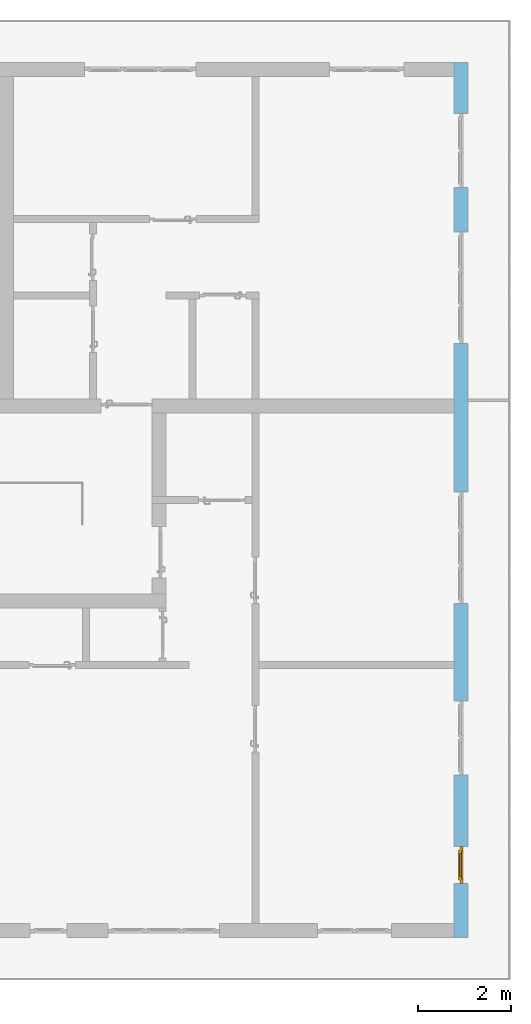
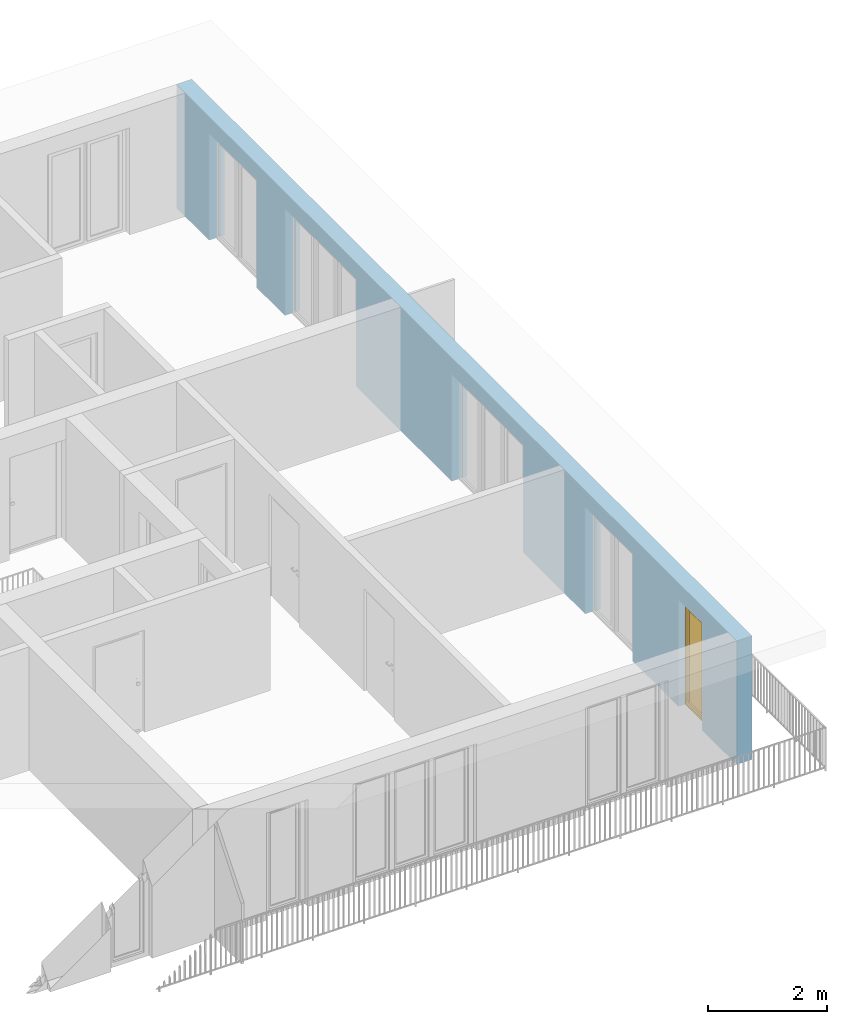
# One storey, part 23 of 54: 1 window, 5 openings, plus 1 element that does not belong to this part.
"""IFC4 building model written with IfcOpenShell, lengths in metres."""

import ifcopenshell
import ifcopenshell.guid

model = None  # the IFC model being written
_history = None  # IfcOwnerHistory: only IFC2X3 demands one
_inside = {}  # id of a spatial element -> (the spatial element, [elements in it])
_under = {}  # id of a project, library or spatial element -> (it, [spatial elements below it])
_declared = {}  # id of a project -> (the project, [libraries it declares])
_typed = {}  # id of a type object -> (the type object, [elements of that type])
_made_of = {}  # id of a material, layer set ... -> (it, [elements and type objects made of it])


def new_model(schema):
    """Start an empty IFC model of exactly this schema.

    Asked for "IFC4X3", IfcOpenShell would pick the latest addendum, in which some entities
    have other attributes; the version numbers below select the first issue.
    IFC2X3 requires an IfcOwnerHistory on every rooted entity: one is made here for all.
    """
    global model, _history
    if schema == "IFC4X3":
        model = ifcopenshell.file(schema_version=(4, 3, 0, 0))
    else:
        model = ifcopenshell.file(schema=schema)
    _inside.clear()
    _under.clear()
    _declared.clear()
    _typed.clear()
    _made_of.clear()
    _history = None
    if model.schema == "IFC2X3":
        org = make("IfcOrganization", Name="unknown")
        user = make(
            "IfcPersonAndOrganization",
            ThePerson=make("IfcPerson", FamilyName="unknown"),
            TheOrganization=org,
        )
        app = make(
            "IfcApplication",
            ApplicationDeveloper=org,
            Version="unknown",
            ApplicationFullName="unknown",
            ApplicationIdentifier="unknown",
        )
        _history = make(
            "IfcOwnerHistory",
            OwningUser=user,
            OwningApplication=app,
            ChangeAction="ADDED",
            CreationDate=0,
        )
    return model


def make(cls, **values):
    """One entity of the class cls with the attributes given. An attribute that is None is left unset."""
    return model.create_entity(
        cls, **{name: value for name, value in values.items() if value is not None}
    )


def entity(cls, *values):
    """Any entity or typed value of the class cls, its attributes in the order of the schema. None: left unset."""
    e = model.create_entity(cls)
    for i, value in enumerate(values):
        if value is not None:
            e[i] = value
    return e


def rooted(cls, **values):
    """An entity with a GlobalId (a new one), such as an element, a storey or a relation."""
    return make(cls, GlobalId=ifcopenshell.guid.new(), OwnerHistory=_history, **values)


def si_unit(unit_type, name, prefix=None):
    """IfcSIUnit, for example si_unit("LENGTHUNIT", "METRE", prefix="MILLI")."""
    return make("IfcSIUnit", UnitType=unit_type, Prefix=prefix, Name=name)


def converted_unit(unit_type, name, factor, base, dimensions=None, offset=None):
    """IfcConversionBasedUnit, such as the inch: factor (a typed value) times the base unit."""
    return make(
        "IfcConversionBasedUnit"
        if offset is None
        else "IfcConversionBasedUnitWithOffset",
        ConversionOffset=offset,
        Dimensions=None
        if dimensions is None
        else entity("IfcDimensionalExponents", *dimensions),
        UnitType=unit_type,
        Name=name,
        ConversionFactor=make(
            "IfcMeasureWithUnit", ValueComponent=factor, UnitComponent=base
        ),
    )


def derived_unit(unit_type, elements):
    """IfcDerivedUnit: a product of units, each with its exponent."""
    return make(
        "IfcDerivedUnit",
        Elements=[
            make("IfcDerivedUnitElement", Unit=unit, Exponent=power)
            for unit, power in elements
        ],
        UnitType=unit_type,
    )


def assignment(units):
    """IfcUnitAssignment: the units of a project."""
    return None if units is None else make("IfcUnitAssignment", Units=units)


def point(xyz):
    """IfcCartesianPoint."""
    return None if xyz is None else make("IfcCartesianPoint", Coordinates=xyz)


def direction(xyz):
    """IfcDirection."""
    return None if xyz is None else make("IfcDirection", DirectionRatios=xyz)


def frame(location, z_axis=None, x_axis=None):
    """IfcAxis2Placement3D, a coordinate frame: its origin and axes. An axis left out is left unset."""
    return make(
        "IfcAxis2Placement3D",
        Location=point(location),
        Axis=direction(z_axis),
        RefDirection=direction(x_axis),
    )


def origin_with_axes():
    """The frame at (0, 0, 0) with the z axis (0, 0, 1) and the x axis (1, 0, 0) written out."""
    return frame((0.0, 0.0, 0.0), z_axis=(0.0, 0.0, 1.0), x_axis=(1.0, 0.0, 0.0))


def place(relative_to, where):
    """IfcLocalPlacement: puts the frame where relative to a parent placement (None: the world)."""
    return make(
        "IfcLocalPlacement", PlacementRelTo=relative_to, RelativePlacement=where
    )


def context(
    kind, dimensions, precision=None, world=None, true_north=None, identifier=None
):
    """IfcGeometricRepresentationContext, for example the 3D "Model" context."""
    return make(
        "IfcGeometricRepresentationContext",
        ContextIdentifier=identifier,
        ContextType=kind,
        CoordinateSpaceDimension=dimensions,
        Precision=precision,
        WorldCoordinateSystem=world,
        TrueNorth=true_north,
    )


def subcontext(parent, identifier, kind, view, scale=None):
    """IfcGeometricRepresentationSubContext, for example "Body" below "Model"."""
    return make(
        "IfcGeometricRepresentationSubContext",
        ContextIdentifier=identifier,
        ContextType=kind,
        ParentContext=parent,
        TargetScale=scale,
        TargetView=view,
    )


def project(units=None, contexts=None):
    """IfcProject with its units and contexts."""
    return rooted(
        "IfcProject",
        Name="project",
        RepresentationContexts=contexts,
        UnitsInContext=assignment(units),
    )


def spatial(cls, under=None, at=None, **own):
    """A site, building, storey or space (cls), placed at a placement, below another one or the project."""
    s = rooted(cls, ObjectPlacement=at, **own)
    if under is not None:
        _under.setdefault(under.id(), (under, []))[1].append(s)
    return s


def point_list(points):
    """IfcCartesianPointList2D or 3D."""
    cls = (
        "IfcCartesianPointList2D" if len(points[0]) == 2 else "IfcCartesianPointList3D"
    )
    return make(cls, CoordList=points)


def polygons(points, faces, closed=None, point_numbers=None):
    """IfcPolygonalFaceSet: a face is its outer loop, then its inner loops; points numbered from 1."""
    made = []
    for loops in faces:
        if len(loops) == 1:
            made.append(make("IfcIndexedPolygonalFace", CoordIndex=loops[0]))
        else:
            made.append(
                make(
                    "IfcIndexedPolygonalFaceWithVoids",
                    CoordIndex=loops[0],
                    InnerCoordIndices=loops[1:],
                )
            )
    return make(
        "IfcPolygonalFaceSet",
        Coordinates=point_list(points),
        Closed=closed,
        Faces=made,
        PnIndex=point_numbers,
    )


def shape(context_of_items, identifier, shape_type, items):
    """IfcShapeRepresentation: the items that make up one representation, for example the "Body"."""
    return make(
        "IfcShapeRepresentation",
        ContextOfItems=context_of_items,
        RepresentationIdentifier=identifier,
        RepresentationType=shape_type,
        Items=items,
    )


def source(mapping_origin, context_of_items, identifier, shape_type, items):
    """IfcRepresentationMap: a shape defined once, which mapped items show again and again."""
    return make(
        "IfcRepresentationMap",
        MappingOrigin=mapping_origin,
        MappedRepresentation=shape(context_of_items, identifier, shape_type, items),
    )


def transform(
    local_origin,
    x_axis=None,
    y_axis=None,
    z_axis=None,
    scale=None,
    scale2=None,
    scale3=None,
    uniform=True,
):
    """IfcCartesianTransformationOperator3D, or its non-uniform kind. x_axis, y_axis, z_axis: its Axis1, 2, 3."""
    if uniform:
        return make(
            "IfcCartesianTransformationOperator3D",
            Axis1=direction(x_axis),
            Axis2=direction(y_axis),
            LocalOrigin=point(local_origin),
            Scale=scale,
            Axis3=direction(z_axis),
        )
    return make(
        "IfcCartesianTransformationOperator3DnonUniform",
        Axis1=direction(x_axis),
        Axis2=direction(y_axis),
        LocalOrigin=point(local_origin),
        Scale=scale,
        Axis3=direction(z_axis),
        Scale2=scale2,
        Scale3=scale3,
    )


def mapped(mapping_source, mapping_target):
    """IfcMappedItem: shows the shape of a source again, moved by a transform."""
    return make(
        "IfcMappedItem", MappingSource=mapping_source, MappingTarget=mapping_target
    )


def material(Name=None, Category=None):
    """IfcMaterial."""
    return make("IfcMaterial", Name=Name, Category=Category)


def made_of(thing, what):
    """Note that an element or type object is made of a material, layer set ...; save() writes the relation."""
    if what is not None:
        _made_of.setdefault(what.id(), (what, []))[1].append(thing)
    return thing


def type_object(cls, material=None, **own):
    """A type object (cls), such as IfcWallType, which elements share."""
    return made_of(rooted(cls, **own), material)


def element(
    cls,
    number,
    at=None,
    inside=None,
    cuts=None,
    type_object=None,
    material=None,
    context=None,
    identifier="Body",
    shape_type=None,
    held_by="IfcProductDefinitionShape",
    body=None,
    shapes=None,
    **own,
):
    """One element of the class cls, such as IfcWall. Its Tag is "e" and its number.

    at: its placement. inside: the storey or other place that contains it. cuts: it is an
    opening in that element (IfcRelVoidsElement). A single representation is given by context,
    identifier, shape_type and body (its items); several are given by shapes. held_by: the class
    of the entity that holds the representations. save() writes the other relations.
    """
    e = rooted(cls, Tag="e%d" % number, ObjectPlacement=at, **own)
    if body is not None:
        shapes = [shape(context, identifier, shape_type, body)]
    if shapes is not None:
        e.Representation = make(held_by, Representations=shapes)
    if inside is not None:
        _inside.setdefault(inside.id(), (inside, []))[1].append(e)
    if cuts is not None:
        rooted(
            "IfcRelVoidsElement", RelatingBuildingElement=cuts, RelatedOpeningElement=e
        )
    if type_object is not None:
        _typed.setdefault(type_object.id(), (type_object, []))[1].append(e)
    return made_of(e, material)


def fill(opening, filler):
    """IfcRelFillsElement: the door or window that sits in an opening."""
    return rooted(
        "IfcRelFillsElement",
        RelatingOpeningElement=opening,
        RelatedBuildingElement=filler,
    )


def aggregate(whole, parts):
    """IfcRelAggregates: a whole, such as a stair, and the parts it consists of."""
    return rooted("IfcRelAggregates", RelatingObject=whole, RelatedObjects=parts)


def save(model, path):
    """Write the relations noted so far, then the file.

    IfcRelAggregates (storeys below a building ...), IfcRelContainedInSpatialStructure (elements
    in a storey), IfcRelDefinesByType, IfcRelAssociatesMaterial and IfcRelDeclares: one each for
    every whole, place, type object, material and project.
    """
    for whole, parts in _under.values():
        aggregate(whole, parts)
    for where, things in _inside.values():
        rooted(
            "IfcRelContainedInSpatialStructure",
            RelatedElements=things,
            RelatingStructure=where,
        )
    for kind, things in _typed.values():
        rooted("IfcRelDefinesByType", RelatedObjects=things, RelatingType=kind)
    for what, things in _made_of.values():
        rooted("IfcRelAssociatesMaterial", RelatedObjects=things, RelatingMaterial=what)
    for by, libraries in _declared.values():
        rooted("IfcRelDeclares", RelatingContext=by, RelatedDefinitions=libraries)
    model.write(path)


model = new_model("IFC4")

# Units and contexts
model_context = context("Model", 3, precision=1e-05, world=origin_with_axes(), true_north=direction((0.0, 1.0)))
body_context = subcontext(model_context, "Body", "Model", "MODEL_VIEW")
ifc_project = project(units=[si_unit("LENGTHUNIT", "METRE"), si_unit("AREAUNIT", "SQUARE_METRE"), si_unit("VOLUMEUNIT", "CUBIC_METRE"), converted_unit("PLANEANGLEUNIT", "DEGREE", entity("IfcPlaneAngleMeasure", 0.0174532925199), si_unit("PLANEANGLEUNIT", "RADIAN"), dimensions=[0, 0, 0, 0, 0, 0, 0]), converted_unit("TIMEUNIT", "Year", entity("IfcTimeMeasure", 31556926.0), si_unit("TIMEUNIT", "SECOND"), dimensions=[0, 0, 1, 0, 0, 0, 0]), si_unit("MASSUNIT", "GRAM", prefix="KILO"), si_unit("THERMODYNAMICTEMPERATUREUNIT", "DEGREE_CELSIUS"), si_unit("LUMINOUSINTENSITYUNIT", "LUMEN"), si_unit("ENERGYUNIT", "JOULE", prefix="MEGA"), derived_unit("THERMALCONDUCTANCEUNIT", [(si_unit("POWERUNIT", "WATT"), 1), (si_unit("LENGTHUNIT", "METRE"), -1), (si_unit("THERMODYNAMICTEMPERATUREUNIT", "KELVIN"), -1)]), derived_unit("SPECIFICHEATCAPACITYUNIT", [(si_unit("ENERGYUNIT", "JOULE"), 1), (si_unit("MASSUNIT", "GRAM", prefix="KILO"), -1), (si_unit("THERMODYNAMICTEMPERATUREUNIT", "KELVIN"), -1)]), derived_unit("MASSDENSITYUNIT", [(si_unit("MASSUNIT", "GRAM", prefix="KILO"), 1), (si_unit("VOLUMEUNIT", "CUBIC_METRE"), -1)])], contexts=[model_context])

# Site, building, storey
site_placement = place(None, origin_with_axes())
site = spatial("IfcSite", under=ifc_project, at=site_placement, CompositionType="ELEMENT")
building_placement = place(site_placement, origin_with_axes())
building = spatial("IfcBuilding", under=site, at=building_placement, CompositionType="ELEMENT")
storey_placement = place(building_placement, frame((0.0, 0.0, 9.18), z_axis=(0.0, 0.0, 1.0), x_axis=(1.0, 0.0, 0.0)))
storey = spatial("IfcBuildingStorey", under=building, at=storey_placement, Name="3. Geschoss", CompositionType="ELEMENT", Elevation=9.18)

# Wall, openings, window
ifc_material = material()
wall_type = type_object("IfcWallType", Name="300", PredefinedType="NOTDEFINED")
wall_placement = place(storey_placement, frame((9.3378006196, -9.92881223104, 0.0), z_axis=(0.0, 0.0, 1.0), x_axis=(0.0, 1.0, 0.0)))
wall = element("IfcWall", 1, at=wall_placement, inside=storey, type_object=wall_type, material=ifc_material, Name="Wand-001", PredefinedType="NOTDEFINED", context=body_context, shape_type="Tessellation", body=[
    polygons([(1.16441876325, 0.1, 2.2), (1.96441876325, 0.1, 2.2), (1.96441876325, 0.0, 2.2), (1.16441876325, 0.0, 2.2), (1.16441876325, 0.3, 2.2), (1.96441876325, 0.3, 2.2), (1.96441876325, 0.1, 0.0), (1.96441876325, 0.0, 0.0), (18.85, 0.0, 2.54), (0.0, 0.0, 2.54), (0.0, 0.0, 0.0), (1.16441876325, 0.0, 0.0), (3.5, 0.0, 0.0), (3.5, 0.0, 2.2), (5.1, 0.0, 2.2), (5.1, 0.0, 0.0), (7.1921181063, 0.0, 0.0), (7.1921181063, 0.0, 2.2), (9.5921181063, 0.0, 2.2), (9.5921181063, 0.0, 0.0), (12.8, 0.0, 0.0), (12.8, 0.0, 2.2), (15.2, 0.0, 2.2), (15.2, 0.0, 0.0), (16.15, 0.0, 0.0), (16.15, 0.0, 2.2), (17.75, 0.0, 2.2), (17.75, 0.0, 0.0), (18.85, 0.0, 0.0), (1.16441876325, 0.1, 0.0), (1.16441876325, 0.3, 0.0), (0.0, 0.3, 0.0), (0.0, 0.3, 2.54), (18.85, 0.3, 2.54), (18.85, 0.3, 0.0), (17.75, 0.3, 0.0), (17.75, 0.3, 2.2), (16.15, 0.3, 2.2), (16.15, 0.3, 0.0), (15.2, 0.3, 0.0), (15.2, 0.3, 2.2), (12.8, 0.3, 2.2), (12.8, 0.3, 0.0), (9.5921181063, 0.3, 0.0), (9.5921181063, 0.3, 2.2), (7.1921181063, 0.3, 2.2), (7.1921181063, 0.3, 0.0), (5.1, 0.3, 0.0), (5.1, 0.3, 2.2), (3.5, 0.3, 2.2), (3.5, 0.3, 0.0), (1.96441876325, 0.3, 0.0), (3.5, 0.1, 0.0), (3.5, 0.1, 2.2), (5.1, 0.1, 2.2), (5.1, 0.1, 0.0), (7.1921181063, 0.1, 0.0), (7.1921181063, 0.1, 2.2), (9.5921181063, 0.1, 2.2), (9.5921181063, 0.1, 0.0), (12.8, 0.1, 0.0), (12.8, 0.1, 2.2), (15.2, 0.1, 2.2), (15.2, 0.1, 0.0), (16.15, 0.1, 0.0), (16.15, 0.1, 2.2), (17.75, 0.1, 2.2), (17.75, 0.1, 0.0)], [[[1, 2, 3, 4]], [[2, 1, 5, 6]], [[2, 7, 8, 3]], [[9, 10, 11, 12, 4, 3, 8, 13, 14, 15, 16, 17, 18, 19, 20, 21, 22, 23, 24, 25, 26, 27, 28, 29]], [[30, 1, 4, 12]], [[1, 30, 31, 5]], [[5, 31, 32, 33, 34, 35, 36, 37, 38, 39, 40, 41, 42, 43, 44, 45, 46, 47, 48, 49, 50, 51, 52, 6]], [[7, 2, 6, 52]], [[7, 52, 51, 53, 13, 8]], [[9, 34, 33, 10]], [[33, 32, 11, 10]], [[31, 30, 12, 11, 32]], [[14, 13, 53, 54]], [[15, 14, 54, 55]], [[16, 15, 55, 56]], [[56, 48, 47, 57, 17, 16]], [[57, 58, 18, 17]], [[58, 59, 19, 18]], [[59, 60, 20, 19]], [[60, 44, 43, 61, 21, 20]], [[22, 21, 61, 62]], [[23, 22, 62, 63]], [[24, 23, 63, 64]], [[64, 40, 39, 65, 25, 24]], [[65, 66, 26, 25]], [[66, 67, 27, 26]], [[67, 68, 28, 27]], [[36, 35, 29, 28, 68]], [[9, 29, 35, 34]], [[68, 67, 37, 36]], [[67, 66, 38, 37]], [[66, 65, 39, 38]], [[41, 40, 64, 63]], [[42, 41, 63, 62]], [[43, 42, 62, 61]], [[60, 59, 45, 44]], [[59, 58, 46, 45]], [[58, 57, 47, 46]], [[49, 48, 56, 55]], [[50, 49, 55, 54]], [[51, 50, 54, 53]]], closed=True),
])
opening_1_placement = place(wall_placement, frame((16.95, 0.0, 0.0), z_axis=(0.0, 0.0, 1.0), x_axis=(1.0, 0.0, 0.0)))
element("IfcOpeningElement", 2, at=opening_1_placement, cuts=wall, Name="Fenster-001", context=body_context, identifier="Reference", shape_type="Tessellation", body=[
    polygons([(0.8, 0.1, 0.0), (0.8, 0.1, 2.2), (0.8, -0.000999999999999, 2.2), (0.8, -0.000999999999999, 0.0), (0.8, 0.301, 0.0), (0.8, 0.301, 2.2), (-0.8, 0.1, 2.2), (-0.8, -0.000999999999999, 2.2), (-0.8, 0.301, 2.2), (-0.8, -0.000999999999999, 0.0), (-0.8, 0.1, 0.0), (-0.8, 0.301, 0.0)], [[[1, 2, 3, 4]], [[2, 1, 5, 6]], [[7, 8, 3, 2, 6, 9]], [[8, 10, 4, 3]], [[1, 4, 10, 11, 12, 5]], [[6, 5, 12, 9]], [[7, 11, 10, 8]], [[11, 7, 9, 12]]], closed=True),
])
opening_2_placement = place(wall_placement, frame((14.0, 0.0, 0.0), z_axis=(0.0, 0.0, 1.0), x_axis=(1.0, 0.0, 0.0)))
element("IfcOpeningElement", 3, at=opening_2_placement, cuts=wall, Name="Fenster-002", context=body_context, identifier="Reference", shape_type="Tessellation", body=[
    polygons([(1.2, 0.1, 0.0), (1.2, 0.1, 2.2), (1.2, -0.000999999999999, 2.2), (1.2, -0.000999999999999, 0.0), (1.2, 0.301, 0.0), (1.2, 0.301, 2.2), (-1.2, 0.1, 2.2), (-1.2, -0.000999999999999, 2.2), (-1.2, 0.301, 2.2), (-1.2, -0.000999999999999, 0.0), (-1.2, 0.1, 0.0), (-1.2, 0.301, 0.0)], [[[1, 2, 3, 4]], [[2, 1, 5, 6]], [[7, 8, 3, 2, 6, 9]], [[8, 10, 4, 3]], [[1, 4, 10, 11, 12, 5]], [[6, 5, 12, 9]], [[7, 11, 10, 8]], [[11, 7, 9, 12]]], closed=True),
])
opening_3_placement = place(wall_placement, frame((8.3921181063, 0.0, 0.0), z_axis=(0.0, 0.0, 1.0), x_axis=(1.0, 0.0, 0.0)))
element("IfcOpeningElement", 4, at=opening_3_placement, cuts=wall, Name="Fenster-002", context=body_context, identifier="Reference", shape_type="Tessellation", body=[
    polygons([(1.2, 0.1, 0.0), (1.2, 0.1, 2.2), (1.2, -0.000999999999999, 2.2), (1.2, -0.000999999999999, 0.0), (1.2, 0.301, 0.0), (1.2, 0.301, 2.2), (-1.2, 0.1, 2.2), (-1.2, -0.000999999999999, 2.2), (-1.2, 0.301, 2.2), (-1.2, -0.000999999999999, 0.0), (-1.2, 0.1, 0.0), (-1.2, 0.301, 0.0)], [[[1, 2, 3, 4]], [[2, 1, 5, 6]], [[7, 8, 3, 2, 6, 9]], [[8, 10, 4, 3]], [[1, 4, 10, 11, 12, 5]], [[6, 5, 12, 9]], [[7, 11, 10, 8]], [[11, 7, 9, 12]]], closed=True),
])
opening_4_placement = place(wall_placement, frame((4.3, 0.0, 0.0), z_axis=(0.0, 0.0, 1.0), x_axis=(1.0, 0.0, 0.0)))
element("IfcOpeningElement", 5, at=opening_4_placement, cuts=wall, Name="Fenster-001", context=body_context, identifier="Reference", shape_type="Tessellation", body=[
    polygons([(0.8, 0.1, 0.0), (0.8, 0.1, 2.2), (0.8, -0.000999999999999, 2.2), (0.8, -0.000999999999999, 0.0), (0.8, 0.301, 0.0), (0.8, 0.301, 2.2), (-0.8, 0.1, 2.2), (-0.8, -0.000999999999999, 2.2), (-0.8, 0.301, 2.2), (-0.8, -0.000999999999999, 0.0), (-0.8, 0.1, 0.0), (-0.8, 0.301, 0.0)], [[[1, 2, 3, 4]], [[2, 1, 5, 6]], [[7, 8, 3, 2, 6, 9]], [[8, 10, 4, 3]], [[1, 4, 10, 11, 12, 5]], [[6, 5, 12, 9]], [[7, 11, 10, 8]], [[11, 7, 9, 12]]], closed=True),
])
opening_5_placement = place(wall_placement, frame((1.56441876325, 0.0, 0.0), z_axis=(0.0, 0.0, 1.0), x_axis=(1.0, 0.0, 0.0)))
opening_5 = element("IfcOpeningElement", 6, at=opening_5_placement, cuts=wall, Name="Fenster-003", context=body_context, identifier="Reference", shape_type="Tessellation", body=[
    polygons([(0.4, 0.1, 0.0), (0.4, 0.1, 2.2), (0.4, -0.000999999999999, 2.2), (0.4, -0.000999999999999, 0.0), (0.4, 0.301, 0.0), (0.4, 0.301, 2.2), (-0.4, 0.1, 2.2), (-0.4, -0.000999999999999, 2.2), (-0.4, 0.301, 2.2), (-0.4, -0.000999999999999, 0.0), (-0.4, 0.1, 0.0), (-0.4, 0.301, 0.0)], [[[1, 2, 3, 4]], [[2, 1, 5, 6]], [[7, 8, 3, 2, 6, 9]], [[8, 10, 4, 3]], [[1, 4, 10, 11, 12, 5]], [[6, 5, 12, 9]], [[7, 11, 10, 8]], [[11, 7, 9, 12]]], closed=True),
])
window_type = type_object("IfcWindowType", Name="1-26", PartitioningType="SINGLE_PANEL", PredefinedType="WINDOW")
shared_shape = source(origin_with_axes(), body_context, "Body", "Tessellation", [
    polygons([(0.4, -0.07, 0.0), (0.3, -0.07, 0.1), (0.3, 0.0, 0.1), (0.4, 0.0, 0.0), (0.4, -0.07, 2.2), (0.3, -0.07, 2.1), (0.3, 0.0, 2.1), (0.4, 0.0, 2.2)], [[[1, 2, 3, 4]], [[1, 5, 6, 2]], [[2, 6, 7, 3]], [[4, 3, 7, 8]], [[5, 1, 4, 8]], [[6, 5, 8, 7]]], closed=True),
    polygons([(-0.4, -0.07, 0.0), (-0.4, -0.07, 2.2), (-0.4, 0.0, 2.2), (-0.4, 0.0, 0.0), (-0.3, -0.07, 0.1), (-0.3, -0.07, 2.1), (-0.3, 0.0, 2.1), (-0.3, 0.0, 0.1)], [[[1, 2, 3, 4]], [[1, 5, 6, 2]], [[2, 6, 7, 3]], [[4, 3, 7, 8]], [[5, 1, 4, 8]], [[6, 5, 8, 7]]], closed=True),
    polygons([(0.4, -0.07, 0.0), (-0.4, -0.07, 0.0), (-0.4, 0.0, 0.0), (0.4, 0.0, 0.0), (0.3, -0.07, 0.1), (0.0, -0.07, 0.1), (-0.3, -0.07, 0.1), (-0.3, 0.0, 0.1), (0.0, 0.0, 0.1), (0.3, 0.0, 0.1)], [[[1, 2, 3, 4]], [[1, 5, 6, 7, 2]], [[2, 7, 8, 3]], [[4, 3, 8, 9, 10]], [[5, 1, 4, 10]], [[6, 5, 10, 9]], [[7, 6, 9, 8]]], closed=True),
    polygons([(0.4, -0.07, 2.2), (0.3, -0.07, 2.1), (0.3, 0.0, 2.1), (0.4, 0.0, 2.2), (-0.4, -0.07, 2.2), (-0.3, -0.07, 2.1), (0.0, -0.07, 2.1), (0.0, 0.0, 2.1), (-0.3, 0.0, 2.1), (-0.4, 0.0, 2.2)], [[[1, 2, 3, 4]], [[1, 5, 6, 7, 2]], [[2, 7, 8, 3]], [[4, 3, 8, 9, 10]], [[5, 1, 4, 10]], [[6, 5, 10, 9]], [[7, 6, 9, 8]]], closed=True),
    polygons([(0.32, 0.0, 0.08), (0.25, 0.0, 0.15), (0.25, 0.03, 0.15), (0.32, 0.03, 0.08), (0.32, 0.0, 2.12), (0.25, 0.0, 2.05), (0.25, 0.03, 2.05), (0.32, 0.03, 2.12)], [[[1, 2, 3, 4]], [[1, 5, 6, 2]], [[2, 6, 7, 3]], [[4, 3, 7, 8]], [[5, 1, 4, 8]], [[6, 5, 8, 7]]], closed=True),
    polygons([(-0.32, 0.0, 0.08), (-0.32, 0.03, 0.08), (-0.25, 0.03, 0.15), (-0.25, 0.0, 0.15), (-0.32, 0.0, 2.12), (-0.32, 0.03, 2.12), (-0.25, 0.03, 2.05), (-0.25, 0.0, 2.05)], [[[1, 2, 3, 4]], [[5, 6, 2, 1]], [[2, 6, 7, 3]], [[4, 3, 7, 8]], [[1, 4, 8, 5]], [[8, 7, 6, 5]]], closed=True),
    polygons([(0.32, 0.0, 0.08), (-0.32, 0.0, 0.08), (-0.32, 0.03, 0.08), (0.32, 0.03, 0.08), (0.25, 0.0, 0.15), (-0.25, 0.0, 0.15), (-0.25, 0.03, 0.15), (0.25, 0.03, 0.15)], [[[1, 2, 3, 4]], [[1, 5, 6, 2]], [[2, 6, 7, 3]], [[4, 3, 7, 8]], [[5, 1, 4, 8]], [[6, 5, 8, 7]]], closed=True),
    polygons([(0.32, 0.0, 2.12), (0.32, 0.03, 2.12), (-0.32, 0.03, 2.12), (-0.32, 0.0, 2.12), (0.25, 0.0, 2.05), (0.25, 0.03, 2.05), (-0.25, 0.03, 2.05), (-0.25, 0.0, 2.05)], [[[1, 2, 3, 4]], [[5, 6, 2, 1]], [[2, 6, 7, 3]], [[4, 3, 7, 8]], [[1, 4, 8, 5]], [[8, 7, 6, 5]]], closed=True),
    polygons([(0.3, -0.03, 0.1), (0.25, -0.03, 0.15), (0.25, 0.0, 0.15), (0.3, 0.0, 0.1), (0.3, -0.03, 2.1), (0.25, -0.03, 2.05), (0.25, 0.0, 2.05), (0.3, 0.0, 2.1)], [[[1, 2, 3, 4]], [[1, 5, 6, 2]], [[2, 6, 7, 3]], [[4, 3, 7, 8]], [[5, 1, 4, 8]], [[6, 5, 8, 7]]], closed=True),
    polygons([(-0.3, -0.03, 0.1), (-0.3, 0.0, 0.1), (-0.25, 0.0, 0.15), (-0.25, -0.03, 0.15), (-0.3, -0.03, 2.1), (-0.3, 0.0, 2.1), (-0.25, 0.0, 2.05), (-0.25, -0.03, 2.05)], [[[1, 2, 3, 4]], [[5, 6, 2, 1]], [[2, 6, 7, 3]], [[4, 3, 7, 8]], [[1, 4, 8, 5]], [[8, 7, 6, 5]]], closed=True),
    polygons([(0.3, -0.03, 0.1), (-0.3, -0.03, 0.1), (-0.3, 0.0, 0.1), (0.3, 0.0, 0.1), (0.25, -0.03, 0.15), (-0.25, -0.03, 0.15), (-0.25, 0.0, 0.15), (0.25, 0.0, 0.15)], [[[1, 2, 3, 4]], [[1, 5, 6, 2]], [[2, 6, 7, 3]], [[4, 3, 7, 8]], [[5, 1, 4, 8]], [[6, 5, 8, 7]]], closed=True),
    polygons([(0.3, -0.03, 2.1), (0.3, 0.0, 2.1), (-0.3, 0.0, 2.1), (-0.3, -0.03, 2.1), (0.25, -0.03, 2.05), (0.25, 0.0, 2.05), (-0.25, 0.0, 2.05), (-0.25, -0.03, 2.05)], [[[1, 2, 3, 4]], [[5, 6, 2, 1]], [[2, 6, 7, 3]], [[4, 3, 7, 8]], [[1, 4, 8, 5]], [[8, 7, 6, 5]]], closed=True),
    polygons([(0.25, -0.005, 0.15), (-0.25, -0.005, 0.15), (-0.25, 0.005, 0.15), (0.25, 0.005, 0.15), (0.25, -0.005, 2.05), (-0.25, -0.005, 2.05), (-0.25, 0.005, 2.05), (0.25, 0.005, 2.05)], [[[1, 2, 3, 4]], [[1, 5, 6, 2]], [[2, 6, 7, 3]], [[4, 3, 7, 8]], [[5, 1, 4, 8]], [[6, 5, 8, 7]]], closed=True),
])
window_placement = place(opening_5_placement, frame((-0.4, 0.0, 0.0), z_axis=(0.0, 0.0, 1.0), x_axis=(1.0, 0.0, 0.0)))
window = element("IfcWindow", 7, at=window_placement, inside=storey, type_object=window_type, Name="Fenster-003", OverallHeight=2.2, OverallWidth=0.8, PredefinedType="WINDOW", context=body_context, shape_type="MappedRepresentation", body=[
    mapped(shared_shape, transform((0.4, 0.17, 0.0))),
])
fill(opening_5, window)

save(model, "model.ifc")
